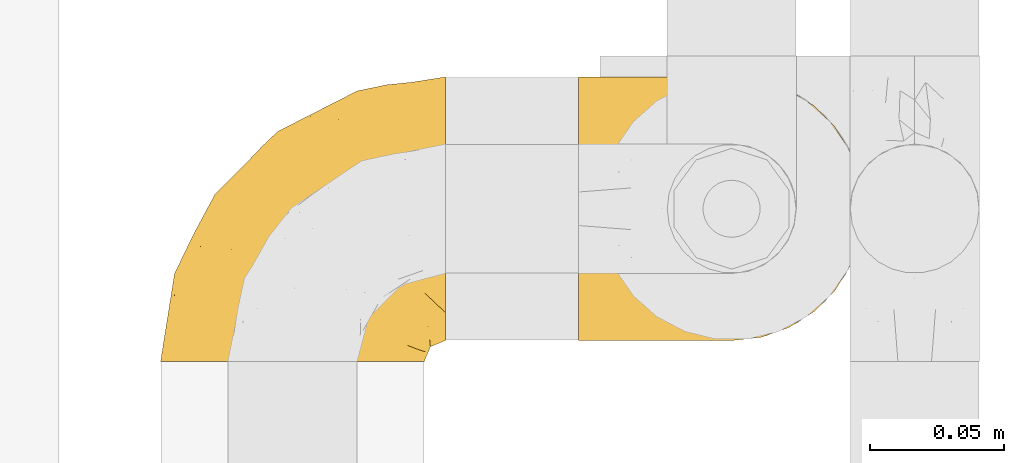
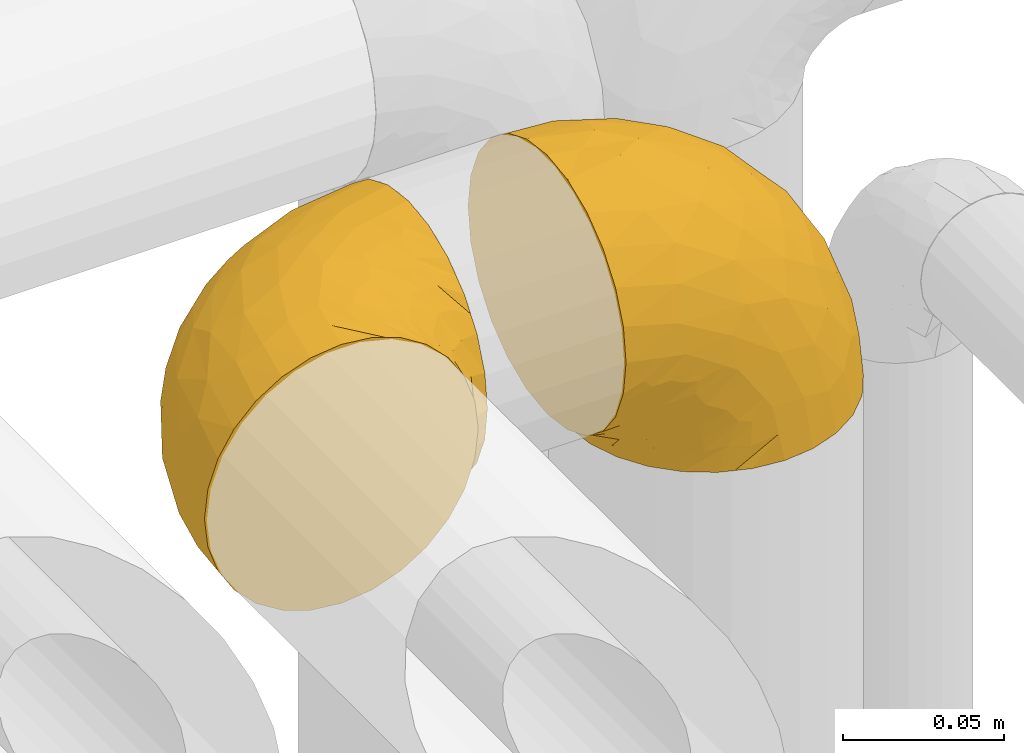
# One storey, part 398 of 827: 2 coverings.
"""IFC2X3 building model written with IfcOpenShell, lengths in millimetres."""

from ifc_helpers import new_model, entity, si_unit, converted_unit, derived_unit, direction, frame, origin, place, context, subcontext, project, spatial, faceted_brep, element, save


model = new_model("IFC2X3")

# Units and contexts
model_context = context("Model", 3, precision=0.01, world=origin(), true_north=direction((6.12303176911189e-17, 1.0)))
body_context = subcontext(model_context, "Body", "Model", "MODEL_VIEW")
ifc_project = project(units=[si_unit("LENGTHUNIT", "METRE", prefix="MILLI"), si_unit("AREAUNIT", "SQUARE_METRE"), si_unit("VOLUMEUNIT", "CUBIC_METRE"), converted_unit("PLANEANGLEUNIT", "DEGREE", entity("IfcRatioMeasure", 0.0174532925199433), si_unit("PLANEANGLEUNIT", "RADIAN"), dimensions=[0, 0, 0, 0, 0, 0, 0]), si_unit("MASSUNIT", "GRAM", prefix="KILO"), derived_unit("MASSDENSITYUNIT", [(si_unit("MASSUNIT", "GRAM", prefix="KILO"), 1), (si_unit("LENGTHUNIT", "METRE"), -3)]), derived_unit("MOMENTOFINERTIAUNIT", [(si_unit("LENGTHUNIT", "METRE"), 4)]), si_unit("TIMEUNIT", "SECOND"), si_unit("FREQUENCYUNIT", "HERTZ"), si_unit("THERMODYNAMICTEMPERATUREUNIT", "DEGREE_CELSIUS"), derived_unit("THERMALTRANSMITTANCEUNIT", [(si_unit("MASSUNIT", "GRAM", prefix="KILO"), 1), (si_unit("THERMODYNAMICTEMPERATUREUNIT", "KELVIN"), -1), (si_unit("TIMEUNIT", "SECOND"), -3)]), derived_unit("VOLUMETRICFLOWRATEUNIT", [(si_unit("LENGTHUNIT", "METRE"), 3), (si_unit("TIMEUNIT", "SECOND"), -1)]), derived_unit("MASSFLOWRATEUNIT", [(si_unit("MASSUNIT", "GRAM", prefix="KILO"), 1), (si_unit("TIMEUNIT", "SECOND"), -1)]), derived_unit("ROTATIONALFREQUENCYUNIT", [(si_unit("TIMEUNIT", "SECOND"), -1)]), si_unit("ELECTRICCURRENTUNIT", "AMPERE"), si_unit("ELECTRICVOLTAGEUNIT", "VOLT"), si_unit("POWERUNIT", "WATT"), si_unit("FORCEUNIT", "NEWTON", prefix="KILO"), si_unit("ILLUMINANCEUNIT", "LUX"), si_unit("LUMINOUSFLUXUNIT", "LUMEN"), si_unit("LUMINOUSINTENSITYUNIT", "CANDELA"), derived_unit("USERDEFINED", [(si_unit("MASSUNIT", "GRAM", prefix="KILO"), -1), (si_unit("LENGTHUNIT", "METRE"), -2), (si_unit("TIMEUNIT", "SECOND"), 3), (si_unit("LUMINOUSFLUXUNIT", "LUMEN"), 1)]), derived_unit("LINEARVELOCITYUNIT", [(si_unit("LENGTHUNIT", "METRE"), 1), (si_unit("TIMEUNIT", "SECOND"), -1)]), si_unit("PRESSUREUNIT", "PASCAL"), derived_unit("USERDEFINED", [(si_unit("LENGTHUNIT", "METRE"), -2), (si_unit("MASSUNIT", "GRAM", prefix="KILO"), 1), (si_unit("TIMEUNIT", "SECOND"), -2)]), derived_unit("LINEARFORCEUNIT", [(si_unit("MASSUNIT", "GRAM", prefix="KILO"), 1), (si_unit("LENGTHUNIT", "METRE"), 1), (si_unit("TIMEUNIT", "SECOND"), -2), (si_unit("LENGTHUNIT", "METRE"), -1)]), derived_unit("PLANARFORCEUNIT", [(si_unit("MASSUNIT", "GRAM", prefix="KILO"), 1), (si_unit("LENGTHUNIT", "METRE"), 1), (si_unit("TIMEUNIT", "SECOND"), -2), (si_unit("LENGTHUNIT", "METRE"), -2)])], contexts=[model_context])

# Site, building, storey
site_placement = place(None, origin())
site = spatial("IfcSite", under=ifc_project, at=site_placement, CompositionType="ELEMENT")
building_placement = place(site_placement, origin())
building = spatial("IfcBuilding", under=site, at=building_placement, CompositionType="ELEMENT")
storey_placement = place(building_placement, frame((0.0, 0.0, 28200.0)))
storey = spatial("IfcBuildingStorey", under=building, at=storey_placement, Name="08", CompositionType="ELEMENT", Elevation=28200.0)

# Coverings
covering_1_placement = place(storey_placement, frame((47437.25, 15092.64, 2949.25)))
element("IfcCovering", 1, at=covering_1_placement, inside=storey, Name=":ADSK_", ObjectType=":ADSK_", PredefinedType="INSULATION", context=body_context, shape_type="Brep", body=[
    faceted_brep([(50.75, 1.6, 99.9), (39.8, 1.6, 98.66), (29.41, 1.6, 95.02), (20.09, 1.6, 89.17), (12.31, 1.6, 81.38), (6.46, 1.6, 72.06), (2.83, 1.6, 61.68), (1.6, 1.6, 50.75), (2.83, 1.6, 39.8), (6.47, 1.6, 29.41), (12.32, 1.6, 20.09), (20.11, 1.6, 12.31), (29.43, 1.6, 6.46), (39.81, 1.6, 2.83), (50.75, 1.6, 1.6), (56.45, 1.6, 2.24), (61.69, 1.6, 2.83), (66.88, 1.6, 4.65), (72.08, 1.6, 6.47), (81.4, 1.6, 12.32), (89.18, 1.6, 20.11), (95.03, 1.6, 29.43), (98.66, 1.6, 39.81), (99.9, 1.6, 50.75), (98.66, 1.6, 61.69), (95.02, 1.6, 72.08), (89.17, 1.6, 81.4), (81.38, 1.6, 89.18), (72.06, 1.6, 95.03), (66.87, 1.6, 96.85), (61.68, 1.6, 98.66), (56.45, 1.6, 99.25), (53.6, 1.6, 99.57), (107.75, 11.12, 38.02), (107.75, 16.03, 26.17), (107.75, 19.94, 21.08), (107.75, 23.84, 15.99), (107.75, 28.93, 12.09), (107.75, 34.02, 8.18), (107.75, 39.95, 5.73), (107.75, 45.87, 3.27), (107.75, 52.86, 2.35), (107.75, 55.73, 1.97), (107.75, 58.6, 1.6), (107.75, 71.32, 3.27), (107.75, 83.17, 8.18), (107.75, 93.35, 15.99), (107.75, 101.16, 26.17), (107.75, 106.07, 38.02), (107.75, 107.75, 50.75), (107.75, 106.07, 63.47), (107.75, 101.16, 75.32), (107.75, 93.35, 85.5), (107.75, 83.17, 93.31), (107.75, 71.32, 98.22), (107.75, 58.6, 99.9), (107.75, 52.86, 99.14), (107.75, 45.87, 98.22), (107.75, 39.95, 95.77), (107.75, 34.02, 93.31), (107.75, 28.93, 89.4), (107.75, 23.84, 85.5), (107.75, 19.94, 80.41), (107.75, 16.03, 75.32), (107.75, 11.12, 63.47), (107.75, 9.45, 50.75), (39.38, 81.82, 59.31), (49.75, 84.02, 73.08), (57.38, 93.05, 63.72), (74.94, 102.55, 50.75), (85.97, 104.83, 58.64), (95.66, 105.83, 50.75), (67.82, 91.87, 76.74), (83.09, 101.74, 67.68), (89.16, 97.07, 78.92), (37.01, 38.45, 94.31), (43.46, 22.17, 98.76), (51.79, 42.04, 98.4), (85.58, 77.69, 94.57), (62.84, 75.76, 89.91), (62.77, 62.11, 96.32), (88.17, 66.08, 98.79), (85.93, 54.26, 99.9), (91.42, 55.35, 99.9), (96.91, 56.44, 99.9), (99.62, 56.98, 99.9), (102.33, 57.52, 99.9), (82.57, 87.84, 87.31), (32.75, 19.41, 95.61), (13.79, 48.89, 60.43), (6.77, 26.34, 65.24), (16.46, 44.55, 72.87), (55.08, 23.41, 99.9), (58.17, 28.03, 99.9), (61.26, 32.65, 99.9), (64.35, 37.28, 99.9), (67.44, 41.9, 99.9), (24.18, 20.6, 90.65), (23.37, 63.36, 63.14), (49.76, 62.21, 91.89), (9.84, 19.94, 75.25), (3.51, 13.68, 50.75), (55.75, 80.85, 82.18), (42.34, 66.53, 85.08), (37.78, 71.06, 76.93), (21.87, 63.99, 50.75), (33.61, 75.73, 50.75), (17.1, 26.77, 83.02), (51.28, 4.31, 99.9), (51.82, 7.01, 99.9), (52.9, 12.43, 99.9), (53.99, 17.92, 99.9), (28.01, 43.43, 87.13), (28.99, 56.23, 80.85), (69.9, 54.97, 99.17), (6.79, 34.4, 50.75), (72.06, 44.99, 99.9), (76.69, 48.08, 99.9), (81.31, 51.17, 99.9), (45.35, 87.47, 50.75), (34.79, 74.55, 67.61), (25.72, 60.86, 72.25), (14.33, 49.19, 50.75), (60.15, 95.01, 50.75), (62.38, 10.27, 98.69), (100.57, 48.79, 99.01), (91.06, 45.16, 98.79), (97.66, 44.99, 98.29), (97.55, 6.17, 68.51), (93.65, 7.65, 76.82), (66.85, 21.59, 98.54), (61.93, 19.96, 99.3), (101.4, 21.0, 83.57), (100.07, 27.2, 89.47), (101.36, 14.83, 75.76), (95.94, 19.7, 84.86), (96.3, 10.93, 75.89), (101.98, 9.63, 64.77), (85.88, 19.97, 90.83), (78.88, 21.13, 94.62), (82.8, 14.14, 90.37), (102.58, 30.2, 91.18), (82.88, 8.12, 88.65), (88.57, 9.93, 84.11), (88.67, 24.62, 91.75), (69.08, 11.87, 96.86), (102.19, 7.15, 50.75), (100.06, 5.32, 58.97), (70.56, 26.68, 98.37), (91.07, 13.92, 83.91), (77.56, 30.67, 97.52), (96.59, 36.65, 95.55), (86.38, 42.89, 98.76), (91.79, 34.04, 95.26), (81.71, 36.6, 98.04), (94.11, 26.41, 90.65), (76.09, 10.07, 93.51), (76.91, 15.83, 94.16), (81.44, 41.99, 99.1), (101.37, 14.83, 25.73), (94.12, 26.4, 10.84), (101.41, 21.01, 17.92), (95.96, 19.71, 16.64), (96.22, 5.72, 30.44), (66.85, 21.6, 2.95), (61.94, 19.96, 2.19), (58.17, 28.03, 1.6), (69.1, 11.87, 4.63), (88.58, 9.93, 17.39), (96.91, 56.44, 1.6), (102.33, 57.52, 1.6), (105.04, 58.06, 1.6), (82.9, 8.13, 12.86), (82.82, 14.15, 11.13), (97.66, 44.99, 3.2), (96.59, 36.65, 5.94), (100.07, 27.21, 12.02), (91.79, 34.04, 6.23), (102.58, 30.2, 10.31), (76.13, 10.06, 8.0), (76.93, 15.83, 7.34), (100.57, 48.79, 2.48), (86.38, 42.89, 2.73), (90.86, 45.38, 2.64), (52.9, 12.43, 1.6), (62.39, 10.28, 2.8), (101.98, 9.64, 36.71), (91.42, 55.35, 1.6), (85.93, 54.26, 1.6), (99.49, 6.05, 38.59), (51.82, 7.01, 1.6), (52.36, 9.72, 1.6), (61.26, 32.65, 1.6), (70.56, 26.68, 3.12), (91.09, 13.92, 17.59), (64.35, 37.28, 1.6), (77.6, 30.66, 3.98), (78.89, 21.14, 6.87), (81.71, 36.59, 3.45), (88.69, 24.6, 9.76), (53.99, 17.92, 1.6), (55.08, 23.41, 1.6), (96.31, 10.93, 25.62), (85.9, 19.97, 10.67), (81.45, 41.99, 2.39), (76.69, 48.08, 1.6), (81.31, 51.17, 1.6), (72.06, 44.99, 1.6), (67.44, 41.9, 1.6), (69.6, 55.26, 2.4), (85.97, 104.83, 42.85), (82.57, 87.84, 14.18), (63.16, 75.91, 11.56), (55.81, 80.84, 19.27), (67.81, 91.87, 24.75), (49.73, 83.98, 28.37), (32.55, 19.16, 5.95), (43.23, 22.37, 2.79), (88.17, 66.08, 2.71), (57.38, 93.05, 37.78), (83.08, 101.74, 33.81), (89.16, 97.07, 22.57), (85.58, 77.69, 6.92), (16.46, 44.55, 28.61), (6.77, 26.34, 36.24), (13.8, 48.9, 41.05), (37.71, 70.99, 24.55), (34.8, 74.55, 33.88), (36.83, 37.8, 7.11), (39.38, 81.82, 42.18), (17.12, 26.77, 18.46), (24.19, 20.6, 10.84), (28.89, 56.15, 20.69), (25.69, 60.85, 29.27), (51.77, 42.06, 3.1), (45.66, 57.03, 9.18), (23.39, 63.4, 38.38), (9.85, 19.94, 26.23), (28.11, 43.59, 14.34), (62.27, 62.61, 5.46), (42.35, 66.52, 16.39)], [[[0, 1, 2, 3, 4, 5, 6, 7, 8, 9, 10, 11, 12, 13, 14, 15, 16, 17, 18, 19, 20, 21, 22, 23, 24, 25, 26, 27, 28, 29, 30, 31, 32]], [[33, 34, 35, 36, 37, 38, 39, 40, 41, 42, 43, 44, 45, 46, 47, 48, 49, 50, 51, 52, 53, 54, 55, 56, 57, 58, 59, 60, 61, 62, 63, 64, 65]], [[66, 67, 68]], [[69, 70, 71]], [[68, 72, 73]], [[73, 72, 74]], [[75, 76, 77]], [[78, 79, 80]], [[51, 50, 73]], [[81, 82, 83, 84, 85, 86, 55]], [[52, 87, 53]], [[74, 52, 51]], [[2, 1, 88]], [[89, 90, 91]], [[77, 92, 93, 94, 95, 96]], [[55, 54, 81]], [[78, 53, 87]], [[5, 90, 6]], [[88, 76, 75]], [[97, 3, 2]], [[89, 91, 98]], [[99, 80, 79]], [[90, 5, 100]], [[74, 87, 52]], [[100, 5, 4]], [[90, 101, 6]], [[79, 102, 103]], [[102, 67, 104]], [[105, 98, 106]], [[107, 4, 3]], [[76, 0, 108, 109, 110, 111, 92]], [[107, 112, 113]], [[114, 77, 96]], [[89, 115, 90]], [[114, 96, 116, 117, 118, 82]], [[75, 97, 88]], [[119, 66, 68]], [[50, 71, 70]], [[100, 91, 90]], [[99, 77, 80]], [[102, 104, 103]], [[97, 107, 3]], [[80, 81, 78]], [[107, 97, 112]], [[68, 73, 70]], [[66, 98, 120]], [[78, 81, 54]], [[114, 81, 80]], [[53, 78, 54]], [[78, 87, 79]], [[102, 87, 72]], [[79, 103, 99]], [[4, 107, 100]], [[91, 100, 107]], [[88, 97, 2]], [[112, 97, 75]], [[99, 112, 75]], [[103, 104, 113]], [[91, 121, 98]], [[89, 105, 122, 115]], [[101, 90, 115]], [[101, 7, 6]], [[88, 1, 76]], [[0, 76, 1]], [[92, 77, 76]], [[73, 74, 51]], [[87, 74, 72]], [[81, 114, 82]], [[77, 114, 80]], [[87, 102, 79]], [[67, 102, 72]], [[68, 67, 72]], [[67, 120, 104]], [[120, 121, 104]], [[104, 121, 113]], [[121, 120, 98]], [[91, 107, 113]], [[91, 113, 121]], [[103, 113, 112]], [[106, 98, 66]], [[105, 89, 98]], [[106, 66, 119]], [[67, 66, 120]], [[68, 69, 123, 119]], [[50, 49, 71]], [[50, 70, 73]], [[112, 99, 103]], [[77, 99, 75]], [[69, 68, 70]], [[29, 124, 110]], [[84, 83, 125]], [[126, 82, 118]], [[59, 58, 127]], [[25, 128, 129]], [[130, 93, 131]], [[132, 62, 133]], [[134, 135, 136]], [[137, 65, 64]], [[64, 134, 137]], [[138, 139, 140]], [[111, 110, 124, 92]], [[134, 136, 137]], [[134, 64, 63]], [[141, 61, 60]], [[125, 58, 57]], [[142, 143, 140]], [[142, 26, 143]], [[127, 83, 82]], [[28, 124, 29]], [[108, 0, 32, 31, 30, 110, 109]], [[30, 29, 110]], [[135, 144, 138]], [[28, 145, 124]], [[57, 56, 55, 86, 85, 84]], [[146, 147, 23]], [[24, 23, 147]], [[25, 143, 26]], [[95, 94, 148]], [[24, 128, 25]], [[149, 138, 143]], [[124, 145, 131]], [[127, 58, 125]], [[150, 148, 139]], [[127, 126, 151]], [[151, 59, 127]], [[152, 151, 126]], [[153, 154, 155]], [[153, 133, 141]], [[145, 28, 27]], [[142, 156, 27]], [[157, 148, 130]], [[61, 133, 62]], [[134, 132, 135]], [[147, 128, 24]], [[65, 137, 146]], [[146, 137, 147]], [[128, 137, 136]], [[137, 128, 147]], [[128, 136, 129]], [[149, 129, 136]], [[25, 129, 143]], [[158, 152, 117]], [[152, 118, 117]], [[153, 151, 152]], [[158, 116, 154]], [[144, 150, 138]], [[153, 152, 158]], [[133, 153, 155]], [[133, 155, 132]], [[60, 151, 141]], [[135, 132, 155]], [[134, 63, 132]], [[144, 135, 155]], [[135, 138, 149]], [[155, 154, 144]], [[150, 154, 96]], [[154, 150, 144]], [[148, 94, 130]], [[82, 126, 127]], [[118, 152, 126]], [[150, 96, 95]], [[139, 148, 157]], [[150, 95, 148]], [[93, 92, 131]], [[130, 145, 156]], [[130, 94, 93]], [[84, 125, 57]], [[127, 125, 83]], [[140, 139, 157]], [[150, 139, 138]], [[140, 157, 142]], [[138, 140, 143]], [[156, 142, 157]], [[27, 26, 142]], [[130, 156, 157]], [[145, 27, 156]], [[132, 63, 62]], [[124, 131, 92]], [[130, 131, 145]], [[129, 149, 143]], [[135, 149, 136]], [[141, 133, 61]], [[60, 59, 151]], [[141, 151, 153]], [[116, 96, 154]], [[153, 158, 154]], [[158, 117, 116]], [[34, 33, 159]], [[160, 161, 162]], [[22, 21, 163]], [[164, 165, 166]], [[19, 18, 167]], [[168, 21, 20]], [[42, 41, 40, 169, 170, 171, 43]], [[172, 173, 168]], [[174, 38, 175]], [[176, 177, 178]], [[179, 164, 180]], [[40, 181, 169]], [[182, 183, 175]], [[17, 184, 185]], [[65, 146, 186]], [[187, 174, 188]], [[23, 22, 189]], [[174, 39, 38]], [[15, 14, 190, 191, 184, 16]], [[181, 40, 39]], [[192, 193, 164]], [[194, 163, 168]], [[33, 186, 159]], [[180, 173, 172]], [[195, 196, 193]], [[18, 185, 167]], [[173, 180, 197]], [[198, 199, 196]], [[200, 201, 185, 184]], [[184, 17, 16]], [[18, 17, 185]], [[202, 159, 186]], [[194, 168, 203]], [[189, 163, 202]], [[204, 205, 182]], [[187, 181, 174]], [[160, 177, 176]], [[206, 183, 182]], [[206, 182, 205]], [[201, 165, 185]], [[165, 164, 167]], [[172, 179, 180]], [[202, 194, 162]], [[176, 161, 160]], [[65, 186, 33]], [[163, 189, 22]], [[175, 177, 182]], [[174, 183, 188]], [[177, 198, 204]], [[199, 160, 162]], [[198, 207, 204]], [[175, 38, 37]], [[198, 177, 160]], [[178, 177, 175]], [[176, 35, 161]], [[34, 159, 161]], [[162, 161, 159]], [[202, 162, 159]], [[199, 162, 203]], [[196, 199, 203]], [[198, 160, 199]], [[193, 197, 180]], [[208, 198, 196]], [[188, 183, 206]], [[175, 183, 174]], [[193, 192, 195]], [[195, 208, 196]], [[197, 196, 203]], [[180, 164, 193]], [[168, 163, 21]], [[166, 165, 201]], [[166, 192, 164]], [[189, 202, 186]], [[186, 146, 189]], [[23, 189, 146]], [[174, 181, 39]], [[169, 181, 187]], [[196, 197, 193]], [[173, 203, 168]], [[203, 173, 197]], [[172, 168, 20]], [[20, 19, 172]], [[179, 172, 19]], [[19, 167, 179]], [[164, 179, 167]], [[35, 176, 36]], [[35, 34, 161]], [[185, 165, 167]], [[162, 194, 203]], [[163, 194, 202]], [[176, 178, 36]], [[37, 36, 178]], [[175, 37, 178]], [[177, 204, 182]], [[207, 198, 208]], [[207, 205, 204]], [[209, 188, 206, 205, 207, 208]], [[48, 210, 71]], [[211, 212, 213]], [[214, 213, 215]], [[216, 217, 13]], [[218, 43, 171, 170, 169, 187, 188]], [[219, 220, 214]], [[47, 46, 221]], [[210, 48, 220]], [[211, 222, 212]], [[222, 45, 44]], [[221, 220, 47]], [[47, 220, 48]], [[221, 211, 214]], [[223, 224, 225]], [[211, 46, 45]], [[226, 227, 215]], [[43, 218, 44]], [[217, 216, 228]], [[219, 215, 229]], [[14, 13, 217]], [[224, 9, 8]], [[10, 230, 11]], [[11, 231, 12]], [[232, 223, 233]], [[234, 208, 195, 192, 166, 201]], [[235, 234, 228]], [[222, 44, 218]], [[106, 229, 236]], [[224, 237, 9]], [[231, 238, 228]], [[9, 237, 10]], [[115, 224, 101]], [[239, 234, 235]], [[231, 11, 230]], [[223, 230, 237]], [[224, 8, 101]], [[223, 236, 233]], [[225, 115, 122, 105]], [[216, 12, 231]], [[209, 234, 239]], [[210, 219, 69]], [[219, 214, 215]], [[229, 119, 219]], [[209, 218, 188]], [[239, 212, 222]], [[239, 222, 218]], [[45, 222, 211]], [[235, 212, 239]], [[213, 212, 240]], [[223, 237, 224]], [[230, 10, 237]], [[238, 231, 230]], [[216, 231, 228]], [[232, 230, 223]], [[235, 238, 240]], [[115, 225, 224]], [[233, 236, 227]], [[8, 7, 101]], [[234, 209, 208]], [[218, 209, 239]], [[217, 228, 234]], [[13, 12, 216]], [[234, 201, 217]], [[217, 201, 200, 184, 191, 190, 14]], [[211, 221, 46]], [[220, 221, 214]], [[71, 210, 69]], [[71, 49, 48]], [[219, 210, 220]], [[226, 215, 213]], [[211, 213, 214]], [[226, 213, 240]], [[215, 227, 229]], [[232, 240, 238]], [[233, 227, 226]], [[232, 233, 226]], [[236, 223, 225]], [[240, 232, 226]], [[232, 238, 230]], [[225, 105, 236]], [[236, 105, 106]], [[236, 229, 227]], [[123, 69, 219, 119]], [[106, 119, 229]], [[238, 235, 228]], [[212, 235, 240]]]),
])
covering_2_placement = place(storey_placement, frame((47593.15, 15100.49, 2941.4)))
element("IfcCovering", 2, at=covering_2_placement, inside=storey, Name=":ADSK_", ObjectType=":ADSK_", PredefinedType="INSULATION", context=body_context, shape_type="Brep", body=[
    faceted_brep([(58.6, 99.9, 1.6), (69.54, 98.66, 1.6), (79.93, 95.02, 1.6), (89.25, 89.17, 1.6), (97.03, 81.38, 1.6), (102.88, 72.06, 1.6), (106.51, 61.68, 1.6), (107.75, 50.75, 1.6), (106.51, 39.8, 1.6), (102.87, 29.41, 1.6), (97.02, 20.09, 1.6), (89.23, 12.31, 1.6), (79.91, 6.46, 1.6), (69.53, 2.83, 1.6), (58.6, 1.6, 1.6), (52.89, 2.24, 1.6), (47.65, 2.83, 1.6), (42.46, 4.65, 1.6), (37.26, 6.47, 1.6), (27.94, 12.32, 1.6), (20.16, 20.11, 1.6), (14.31, 29.43, 1.6), (10.68, 39.81, 1.6), (9.45, 50.75, 1.6), (10.68, 61.69, 1.6), (14.32, 72.08, 1.6), (20.17, 81.4, 1.6), (27.96, 89.18, 1.6), (37.28, 95.03, 1.6), (42.47, 96.85, 1.6), (47.66, 98.66, 1.6), (52.89, 99.25, 1.6), (55.75, 99.57, 1.6), (1.6, 38.02, 11.12), (1.6, 26.17, 16.03), (1.6, 21.08, 19.94), (1.6, 15.99, 23.84), (1.6, 12.09, 28.93), (1.6, 8.18, 34.02), (1.6, 5.73, 39.95), (1.6, 3.27, 45.87), (1.6, 2.35, 52.86), (1.6, 1.97, 55.73), (1.6, 1.6, 58.6), (1.6, 3.27, 71.32), (1.6, 8.18, 83.17), (1.6, 15.99, 93.35), (1.6, 26.17, 101.16), (1.6, 38.02, 106.07), (1.6, 50.75, 107.75), (1.6, 63.47, 106.07), (1.6, 75.32, 101.16), (1.6, 85.5, 93.35), (1.6, 93.31, 83.17), (1.6, 98.22, 71.32), (1.6, 99.9, 58.6), (1.6, 99.14, 52.86), (1.6, 98.22, 45.87), (1.6, 95.77, 39.95), (1.6, 93.31, 34.02), (1.6, 89.4, 28.93), (1.6, 85.5, 23.84), (1.6, 80.41, 19.94), (1.6, 75.32, 16.03), (1.6, 63.47, 11.12), (1.6, 50.75, 9.45), (69.96, 59.31, 81.82), (59.59, 73.08, 84.02), (51.96, 63.72, 93.05), (34.4, 50.75, 102.55), (23.37, 58.64, 104.83), (13.68, 50.75, 105.83), (41.52, 76.74, 91.87), (26.26, 67.68, 101.74), (20.18, 78.92, 97.07), (72.33, 94.31, 38.45), (65.88, 98.76, 22.17), (57.55, 98.4, 42.04), (23.76, 94.57, 77.69), (46.5, 89.91, 75.76), (46.57, 96.32, 62.11), (21.17, 98.79, 66.08), (23.41, 99.9, 54.26), (17.92, 99.9, 55.35), (12.43, 99.9, 56.44), (9.72, 99.9, 56.98), (7.01, 99.9, 57.52), (26.77, 87.31, 87.84), (76.59, 95.61, 19.41), (95.55, 60.43, 48.89), (102.57, 65.24, 26.34), (92.89, 72.87, 44.55), (54.26, 99.9, 23.41), (51.17, 99.9, 28.03), (48.08, 99.9, 32.65), (44.99, 99.9, 37.28), (41.9, 99.9, 41.9), (85.16, 90.65, 20.6), (85.97, 63.14, 63.36), (59.58, 91.89, 62.21), (99.5, 75.25, 19.94), (105.83, 50.75, 13.68), (53.59, 82.18, 80.85), (67.0, 85.08, 66.53), (71.56, 76.93, 71.06), (87.47, 50.75, 63.99), (75.73, 50.75, 75.73), (92.24, 83.02, 26.77), (58.06, 99.9, 4.31), (57.52, 99.9, 7.01), (56.44, 99.9, 12.43), (55.35, 99.9, 17.92), (81.33, 87.13, 43.43), (80.35, 80.85, 56.23), (39.44, 99.17, 54.97), (102.55, 50.75, 34.4), (37.28, 99.9, 44.99), (32.65, 99.9, 48.08), (28.03, 99.9, 51.17), (63.99, 50.75, 87.47), (74.55, 67.61, 74.55), (83.62, 72.25, 60.86), (95.01, 50.75, 49.19), (49.19, 50.75, 95.01), (46.96, 98.69, 10.27), (8.77, 99.01, 48.79), (18.28, 98.79, 45.16), (11.68, 98.29, 44.99), (11.79, 68.51, 6.17), (15.69, 76.82, 7.65), (42.49, 98.54, 21.59), (47.41, 99.3, 19.96), (7.94, 83.57, 21.0), (9.27, 89.47, 27.2), (7.98, 75.76, 14.83), (13.4, 84.86, 19.7), (13.04, 75.89, 10.93), (7.36, 64.77, 9.63), (23.46, 90.83, 19.97), (30.46, 94.62, 21.13), (26.54, 90.37, 14.14), (6.76, 91.18, 30.2), (26.46, 88.65, 8.12), (20.77, 84.11, 9.93), (20.68, 91.75, 24.62), (40.26, 96.86, 11.87), (7.15, 50.75, 7.15), (9.28, 58.97, 5.32), (38.78, 98.37, 26.68), (18.27, 83.91, 13.92), (31.78, 97.52, 30.67), (12.75, 95.55, 36.65), (22.96, 98.76, 42.89), (17.55, 95.26, 34.04), (27.63, 98.04, 36.6), (15.23, 90.65, 26.41), (33.25, 93.51, 10.07), (32.43, 94.16, 15.83), (27.9, 99.1, 41.99), (7.97, 25.73, 14.83), (15.22, 10.84, 26.4), (7.93, 17.92, 21.01), (13.38, 16.64, 19.71), (13.12, 30.44, 5.72), (42.49, 2.95, 21.6), (47.4, 2.19, 19.96), (51.17, 1.6, 28.03), (40.24, 4.63, 11.87), (20.76, 17.39, 9.93), (12.43, 1.6, 56.44), (7.01, 1.6, 57.52), (4.31, 1.6, 58.06), (26.44, 12.86, 8.13), (26.52, 11.13, 14.15), (11.68, 3.2, 44.99), (12.75, 5.94, 36.65), (9.27, 12.02, 27.21), (17.55, 6.23, 34.04), (6.76, 10.31, 30.2), (33.21, 8.0, 10.06), (32.41, 7.34, 15.83), (8.77, 2.48, 48.79), (22.96, 2.73, 42.89), (18.48, 2.64, 45.38), (56.44, 1.6, 12.43), (46.95, 2.8, 10.28), (7.36, 36.71, 9.64), (17.92, 1.6, 55.35), (23.41, 1.6, 54.26), (9.85, 38.59, 6.05), (57.52, 1.6, 7.01), (56.98, 1.6, 9.72), (48.08, 1.6, 32.65), (38.78, 3.12, 26.68), (18.25, 17.59, 13.92), (44.99, 1.6, 37.28), (31.74, 3.98, 30.66), (30.45, 6.87, 21.14), (27.63, 3.45, 36.59), (20.65, 9.76, 24.6), (55.35, 1.6, 17.92), (54.26, 1.6, 23.41), (13.03, 25.62, 10.93), (23.44, 10.67, 19.97), (27.9, 2.39, 41.99), (32.65, 1.6, 48.08), (28.03, 1.6, 51.17), (37.28, 1.6, 44.99), (41.9, 1.6, 41.9), (39.74, 2.4, 55.26), (23.37, 42.85, 104.83), (26.77, 14.18, 87.84), (46.18, 11.56, 75.91), (53.54, 19.27, 80.84), (41.53, 24.75, 91.87), (59.61, 28.37, 83.98), (76.79, 5.95, 19.16), (66.11, 2.79, 22.37), (21.17, 2.71, 66.08), (51.96, 37.78, 93.05), (26.26, 33.81, 101.74), (20.18, 22.57, 97.07), (23.76, 6.92, 77.69), (92.88, 28.61, 44.55), (102.57, 36.24, 26.34), (95.54, 41.05, 48.9), (71.63, 24.55, 70.99), (74.55, 33.88, 74.55), (72.51, 7.11, 37.8), (69.96, 42.18, 81.82), (92.23, 18.46, 26.77), (85.15, 10.84, 20.6), (80.45, 20.69, 56.15), (83.65, 29.27, 60.85), (57.57, 3.1, 42.06), (63.68, 9.18, 57.03), (85.95, 38.38, 63.4), (99.49, 26.23, 19.94), (81.23, 14.34, 43.59), (47.07, 5.46, 62.61), (66.99, 16.39, 66.52)], [[[0, 1, 2, 3, 4, 5, 6, 7, 8, 9, 10, 11, 12, 13, 14, 15, 16, 17, 18, 19, 20, 21, 22, 23, 24, 25, 26, 27, 28, 29, 30, 31, 32]], [[33, 34, 35, 36, 37, 38, 39, 40, 41, 42, 43, 44, 45, 46, 47, 48, 49, 50, 51, 52, 53, 54, 55, 56, 57, 58, 59, 60, 61, 62, 63, 64, 65]], [[66, 67, 68]], [[69, 70, 71]], [[68, 72, 73]], [[73, 72, 74]], [[75, 76, 77]], [[78, 79, 80]], [[51, 50, 73]], [[81, 82, 83, 84, 85, 86, 55]], [[52, 87, 53]], [[74, 52, 51]], [[2, 1, 88]], [[89, 90, 91]], [[77, 92, 93, 94, 95, 96]], [[55, 54, 81]], [[78, 53, 87]], [[5, 90, 6]], [[88, 76, 75]], [[97, 3, 2]], [[89, 91, 98]], [[99, 80, 79]], [[90, 5, 100]], [[74, 87, 52]], [[100, 5, 4]], [[90, 101, 6]], [[79, 102, 103]], [[102, 67, 104]], [[105, 98, 106]], [[107, 4, 3]], [[76, 0, 108, 109, 110, 111, 92]], [[107, 112, 113]], [[114, 77, 96]], [[89, 115, 90]], [[114, 96, 116, 117, 118, 82]], [[75, 97, 88]], [[119, 66, 68]], [[50, 71, 70]], [[100, 91, 90]], [[99, 77, 80]], [[102, 104, 103]], [[97, 107, 3]], [[80, 81, 78]], [[107, 97, 112]], [[68, 73, 70]], [[66, 98, 120]], [[78, 81, 54]], [[114, 81, 80]], [[53, 78, 54]], [[78, 87, 79]], [[102, 87, 72]], [[79, 103, 99]], [[4, 107, 100]], [[91, 100, 107]], [[88, 97, 2]], [[112, 97, 75]], [[99, 112, 75]], [[103, 104, 113]], [[91, 121, 98]], [[89, 105, 122, 115]], [[101, 90, 115]], [[101, 7, 6]], [[88, 1, 76]], [[0, 76, 1]], [[92, 77, 76]], [[73, 74, 51]], [[87, 74, 72]], [[81, 114, 82]], [[77, 114, 80]], [[87, 102, 79]], [[67, 102, 72]], [[68, 67, 72]], [[67, 120, 104]], [[120, 121, 104]], [[104, 121, 113]], [[121, 120, 98]], [[91, 107, 113]], [[91, 113, 121]], [[103, 113, 112]], [[106, 98, 66]], [[105, 89, 98]], [[106, 66, 119]], [[67, 66, 120]], [[68, 69, 123, 119]], [[50, 49, 71]], [[50, 70, 73]], [[112, 99, 103]], [[77, 99, 75]], [[69, 68, 70]], [[29, 124, 110]], [[84, 83, 125]], [[126, 82, 118]], [[59, 58, 127]], [[25, 128, 129]], [[130, 93, 131]], [[132, 62, 133]], [[134, 135, 136]], [[137, 65, 64]], [[64, 134, 137]], [[138, 139, 140]], [[111, 110, 124, 92]], [[134, 136, 137]], [[134, 64, 63]], [[141, 61, 60]], [[125, 58, 57]], [[142, 143, 140]], [[142, 26, 143]], [[127, 83, 82]], [[28, 124, 29]], [[108, 0, 32, 31, 30, 110, 109]], [[30, 29, 110]], [[135, 144, 138]], [[28, 145, 124]], [[57, 56, 55, 86, 85, 84]], [[146, 147, 23]], [[24, 23, 147]], [[25, 143, 26]], [[95, 94, 148]], [[24, 128, 25]], [[149, 138, 143]], [[124, 145, 131]], [[127, 58, 125]], [[150, 148, 139]], [[127, 126, 151]], [[151, 59, 127]], [[152, 151, 126]], [[153, 154, 155]], [[153, 133, 141]], [[145, 28, 27]], [[142, 156, 27]], [[157, 148, 130]], [[61, 133, 62]], [[134, 132, 135]], [[147, 128, 24]], [[65, 137, 146]], [[146, 137, 147]], [[128, 137, 136]], [[137, 128, 147]], [[128, 136, 129]], [[149, 129, 136]], [[25, 129, 143]], [[158, 152, 117]], [[152, 118, 117]], [[153, 151, 152]], [[158, 116, 154]], [[144, 150, 138]], [[153, 152, 158]], [[133, 153, 155]], [[133, 155, 132]], [[60, 151, 141]], [[135, 132, 155]], [[134, 63, 132]], [[144, 135, 155]], [[135, 138, 149]], [[155, 154, 144]], [[150, 154, 96]], [[154, 150, 144]], [[148, 94, 130]], [[82, 126, 127]], [[118, 152, 126]], [[150, 96, 95]], [[139, 148, 157]], [[150, 95, 148]], [[93, 92, 131]], [[130, 145, 156]], [[130, 94, 93]], [[84, 125, 57]], [[127, 125, 83]], [[140, 139, 157]], [[150, 139, 138]], [[140, 157, 142]], [[138, 140, 143]], [[156, 142, 157]], [[27, 26, 142]], [[130, 156, 157]], [[145, 27, 156]], [[132, 63, 62]], [[124, 131, 92]], [[130, 131, 145]], [[129, 149, 143]], [[135, 149, 136]], [[141, 133, 61]], [[60, 59, 151]], [[141, 151, 153]], [[116, 96, 154]], [[153, 158, 154]], [[158, 117, 116]], [[34, 33, 159]], [[160, 161, 162]], [[22, 21, 163]], [[164, 165, 166]], [[19, 18, 167]], [[168, 21, 20]], [[42, 41, 40, 169, 170, 171, 43]], [[172, 173, 168]], [[174, 38, 175]], [[176, 177, 178]], [[179, 164, 180]], [[40, 181, 169]], [[182, 183, 175]], [[17, 184, 185]], [[65, 146, 186]], [[187, 174, 188]], [[23, 22, 189]], [[174, 39, 38]], [[15, 14, 190, 191, 184, 16]], [[181, 40, 39]], [[192, 193, 164]], [[194, 163, 168]], [[33, 186, 159]], [[180, 173, 172]], [[195, 196, 193]], [[18, 185, 167]], [[173, 180, 197]], [[198, 199, 196]], [[200, 201, 185, 184]], [[184, 17, 16]], [[18, 17, 185]], [[202, 159, 186]], [[194, 168, 203]], [[189, 163, 202]], [[204, 205, 182]], [[187, 181, 174]], [[160, 177, 176]], [[206, 183, 182]], [[206, 182, 205]], [[201, 165, 185]], [[165, 164, 167]], [[172, 179, 180]], [[202, 194, 162]], [[176, 161, 160]], [[65, 186, 33]], [[163, 189, 22]], [[175, 177, 182]], [[174, 183, 188]], [[177, 198, 204]], [[199, 160, 162]], [[198, 207, 204]], [[175, 38, 37]], [[198, 177, 160]], [[178, 177, 175]], [[176, 35, 161]], [[34, 159, 161]], [[162, 161, 159]], [[202, 162, 159]], [[199, 162, 203]], [[196, 199, 203]], [[198, 160, 199]], [[193, 197, 180]], [[208, 198, 196]], [[188, 183, 206]], [[175, 183, 174]], [[193, 192, 195]], [[195, 208, 196]], [[197, 196, 203]], [[180, 164, 193]], [[168, 163, 21]], [[166, 165, 201]], [[166, 192, 164]], [[189, 202, 186]], [[186, 146, 189]], [[23, 189, 146]], [[174, 181, 39]], [[169, 181, 187]], [[196, 197, 193]], [[173, 203, 168]], [[203, 173, 197]], [[172, 168, 20]], [[20, 19, 172]], [[179, 172, 19]], [[19, 167, 179]], [[164, 179, 167]], [[35, 176, 36]], [[35, 34, 161]], [[185, 165, 167]], [[162, 194, 203]], [[163, 194, 202]], [[176, 178, 36]], [[37, 36, 178]], [[175, 37, 178]], [[177, 204, 182]], [[207, 198, 208]], [[207, 205, 204]], [[209, 188, 206, 205, 207, 208]], [[48, 210, 71]], [[211, 212, 213]], [[214, 213, 215]], [[216, 217, 13]], [[218, 43, 171, 170, 169, 187, 188]], [[219, 220, 214]], [[47, 46, 221]], [[210, 48, 220]], [[211, 222, 212]], [[222, 45, 44]], [[221, 220, 47]], [[47, 220, 48]], [[221, 211, 214]], [[223, 224, 225]], [[211, 46, 45]], [[226, 227, 215]], [[43, 218, 44]], [[217, 216, 228]], [[219, 215, 229]], [[14, 13, 217]], [[224, 9, 8]], [[10, 230, 11]], [[11, 231, 12]], [[232, 223, 233]], [[234, 208, 195, 192, 166, 201]], [[235, 234, 228]], [[222, 44, 218]], [[106, 229, 236]], [[224, 237, 9]], [[231, 238, 228]], [[9, 237, 10]], [[115, 224, 101]], [[239, 234, 235]], [[231, 11, 230]], [[223, 230, 237]], [[224, 8, 101]], [[223, 236, 233]], [[225, 115, 122, 105]], [[216, 12, 231]], [[209, 234, 239]], [[210, 219, 69]], [[219, 214, 215]], [[229, 119, 219]], [[209, 218, 188]], [[239, 212, 222]], [[239, 222, 218]], [[45, 222, 211]], [[235, 212, 239]], [[213, 212, 240]], [[223, 237, 224]], [[230, 10, 237]], [[238, 231, 230]], [[216, 231, 228]], [[232, 230, 223]], [[235, 238, 240]], [[115, 225, 224]], [[233, 236, 227]], [[8, 7, 101]], [[234, 209, 208]], [[218, 209, 239]], [[217, 228, 234]], [[13, 12, 216]], [[234, 201, 217]], [[217, 201, 200, 184, 191, 190, 14]], [[211, 221, 46]], [[220, 221, 214]], [[71, 210, 69]], [[71, 49, 48]], [[219, 210, 220]], [[226, 215, 213]], [[211, 213, 214]], [[226, 213, 240]], [[215, 227, 229]], [[232, 240, 238]], [[233, 227, 226]], [[232, 233, 226]], [[236, 223, 225]], [[240, 232, 226]], [[232, 238, 230]], [[225, 105, 236]], [[236, 105, 106]], [[236, 229, 227]], [[123, 69, 219, 119]], [[106, 119, 229]], [[238, 235, 228]], [[212, 235, 240]]]),
])

save(model, "model.ifc")
